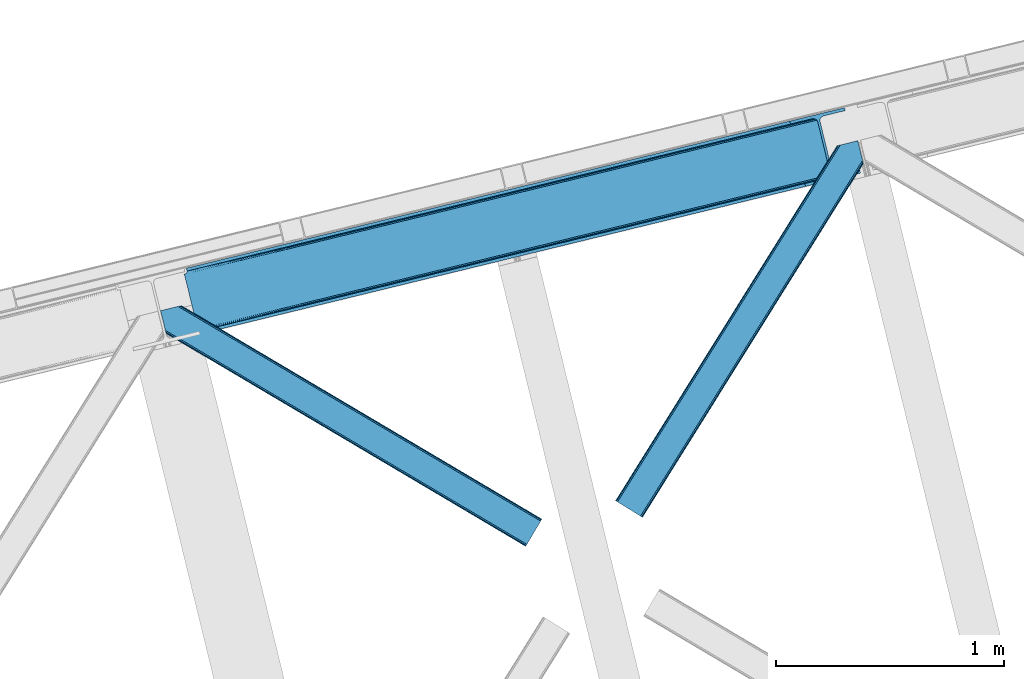
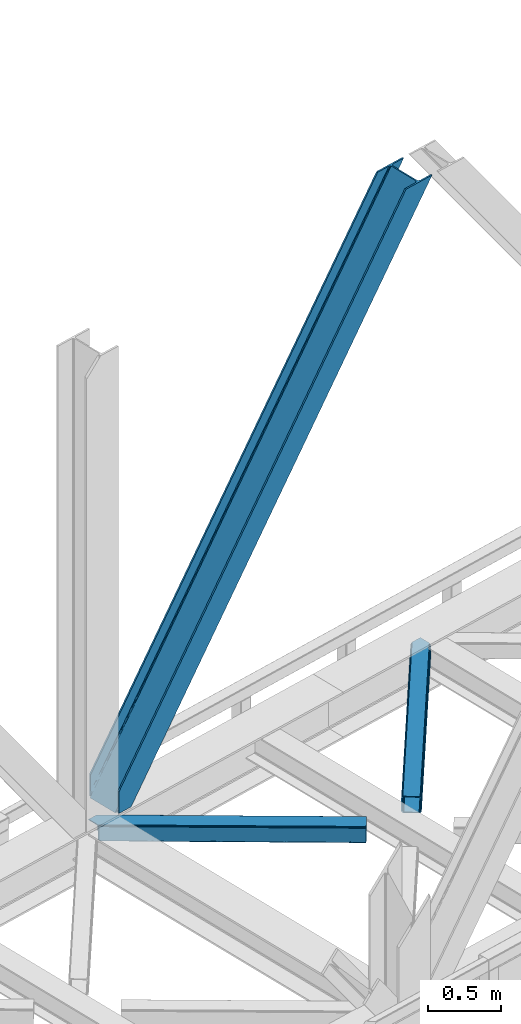
# One storey, part 64 of 92: 3 members.
"""IFC4 building model written with IfcOpenShell, lengths in millimetres."""

from ifc_helpers import new_model, entity, si_unit, converted_unit, derived_unit, direction, frame, origin, place, context, subcontext, project, spatial, triangles, type_object, element, save


model = new_model("IFC4")

# Units and contexts
model_context = context("Model", 3, precision=0.01, world=origin(), true_north=direction((6.12303176911189e-17, 1.0)))
plan_context = context("Plan", 3, precision=0.01, world=origin(), true_north=direction((6.12303176911189e-17, 1.0)))
body_context = subcontext(model_context, "Body", "Model", "MODEL_VIEW")
ifc_project = project(units=[si_unit("LENGTHUNIT", "METRE", prefix="MILLI"), si_unit("AREAUNIT", "SQUARE_METRE"), si_unit("VOLUMEUNIT", "CUBIC_METRE"), converted_unit("PLANEANGLEUNIT", "DEGREE", entity("IfcRatioMeasure", 0.0174532925199433), si_unit("PLANEANGLEUNIT", "RADIAN"), dimensions=[0, 0, 0, 0, 0, 0, 0]), si_unit("MASSUNIT", "GRAM", prefix="KILO"), derived_unit("MASSDENSITYUNIT", [(si_unit("MASSUNIT", "GRAM", prefix="KILO"), 1), (si_unit("LENGTHUNIT", "METRE"), -3)]), derived_unit("MOMENTOFINERTIAUNIT", [(si_unit("LENGTHUNIT", "METRE"), 4)]), si_unit("TIMEUNIT", "SECOND"), si_unit("FREQUENCYUNIT", "HERTZ"), si_unit("THERMODYNAMICTEMPERATUREUNIT", "DEGREE_CELSIUS"), derived_unit("THERMALTRANSMITTANCEUNIT", [(si_unit("MASSUNIT", "GRAM", prefix="KILO"), 1), (si_unit("THERMODYNAMICTEMPERATUREUNIT", "KELVIN"), -1), (si_unit("TIMEUNIT", "SECOND"), -3)]), derived_unit("VOLUMETRICFLOWRATEUNIT", [(si_unit("LENGTHUNIT", "METRE"), 3), (si_unit("TIMEUNIT", "SECOND"), -1)]), derived_unit("MASSFLOWRATEUNIT", [(si_unit("MASSUNIT", "GRAM", prefix="KILO"), 1), (si_unit("TIMEUNIT", "SECOND"), -1)]), derived_unit("ROTATIONALFREQUENCYUNIT", [(si_unit("TIMEUNIT", "SECOND"), -1)]), si_unit("ELECTRICCURRENTUNIT", "AMPERE"), si_unit("ELECTRICVOLTAGEUNIT", "VOLT"), si_unit("POWERUNIT", "WATT"), si_unit("FORCEUNIT", "NEWTON", prefix="KILO"), si_unit("ILLUMINANCEUNIT", "LUX"), si_unit("LUMINOUSFLUXUNIT", "LUMEN"), si_unit("LUMINOUSINTENSITYUNIT", "CANDELA"), derived_unit("USERDEFINED", [(si_unit("MASSUNIT", "GRAM", prefix="KILO"), -1), (si_unit("LENGTHUNIT", "METRE"), -2), (si_unit("TIMEUNIT", "SECOND"), 3), (si_unit("LUMINOUSFLUXUNIT", "LUMEN"), 1)]), derived_unit("LINEARVELOCITYUNIT", [(si_unit("LENGTHUNIT", "METRE"), 1), (si_unit("TIMEUNIT", "SECOND"), -1)]), si_unit("PRESSUREUNIT", "PASCAL"), derived_unit("USERDEFINED", [(si_unit("LENGTHUNIT", "METRE"), -2), (si_unit("MASSUNIT", "GRAM", prefix="KILO"), 1), (si_unit("TIMEUNIT", "SECOND"), -2)]), derived_unit("LINEARFORCEUNIT", [(si_unit("MASSUNIT", "GRAM", prefix="KILO"), 1), (si_unit("LENGTHUNIT", "METRE"), 1), (si_unit("TIMEUNIT", "SECOND"), -2), (si_unit("LENGTHUNIT", "METRE"), -1)]), derived_unit("PLANARFORCEUNIT", [(si_unit("MASSUNIT", "GRAM", prefix="KILO"), 1), (si_unit("LENGTHUNIT", "METRE"), 1), (si_unit("TIMEUNIT", "SECOND"), -2), (si_unit("LENGTHUNIT", "METRE"), -2)])], contexts=[model_context, plan_context])

# Site, building, storey
site_placement = place(None, origin())
site = spatial("IfcSite", under=ifc_project, at=site_placement, CompositionType="ELEMENT")
building_placement = place(site_placement, origin())
building = spatial("IfcBuilding", under=site, at=building_placement, CompositionType="ELEMENT")
storey_placement = place(building_placement, frame((0.0, 0.0, 15900.0)))
storey = spatial("IfcBuildingStorey", under=building, at=storey_placement, Name="05", CompositionType="ELEMENT", Elevation=15900.0)

# Members
member_type_1 = type_object("IfcMemberType", PredefinedType="BRACE")
member_1_placement = place(storey_placement, frame((-23912.66, 14831.12, 3695.0)))
element("IfcMember", 1, at=member_1_placement, inside=storey, type_object=member_type_1, ObjectType="Steel Vertical Brace", PredefinedType="BRACE", context=body_context, shape_type="Tessellation", body=[
    triangles([(58.5452636718765, 26.6239562988267, 0.0), (60.4404968261733, 18.8511749267564, 0.0), (59.1033691406265, 19.6697296142574, 0.80925292968459), (58.9708190917991, 18.4930572509766, 1.10690917968532), (64.0867858886741, 19.7406555175767, 8.31577148437282), (64.0867858886741, 19.7406555175767, 0.0), (522.905291748048, 126.716683959959, 658.855133056641), (68.3748962402351, 19.9232025146484, 14.8293273925774), (72.4072082519524, 18.4523620605469, 22.4381652832017), (524.584259033203, 133.136059570312, 656.552947998047), (73.9861816406265, 17.2873168945298, 26.4425720214822), (2834.75487670899, 696.263314819334, 3911.00081176758), (2834.77115478516, 703.35823059082, 3911.00081176758), (2385.95203857422, 593.953280639647, 3278.7231262207), (2386.50781860352, 586.999053955078, 3279.53005371094), (2831.44112548828, 689.4462890625, 3911.00081176758), (2384.82652587891, 580.578515624999, 3281.83223876953), (2825.33917236328, 683.941973876952, 3911.00081176758), (2381.17326049805, 575.671838378905, 3285.27854003906), (2817.37686767578, 680.591015624999, 3911.00081176758), (2376.09450073242, 573.023162841797, 3289.34108276367), (514.168615722658, 119.160168457031, 666.36397705078), (519.249700927736, 121.807681274413, 662.301434326171), (77.0976196289084, 12.6189971923814, 50.6410949707024), (76.5674194335952, 13.8991516113274, 38.6743835449197), (75.4046997070327, 15.4258026123043, 33.1630920410134), (524.026153564453, 140.089123535156, 655.74602050781), (990.065148925783, 246.601226806641, 1312.29896850586), (989.509368896484, 253.55545349121, 1311.48971557617), (1455.54603881836, 360.067556762695, 1968.04266357422), (1454.99025878906, 367.021783447264, 1967.23341064453), (1921.02692871094, 473.532723999022, 2623.78635864258), (1920.47114868164, 480.48811340332, 2622.97710571289), (988.383856201173, 240.181851196288, 1314.598828125), (1453.86474609375, 353.647018432617, 1970.34484863281), (1919.34563598633, 467.113348388672, 2626.08854370117), (984.730590820313, 235.274011230467, 1318.04512939453), (1450.21148071289, 348.740341186523, 1973.78882446289), (1915.69237060547, 462.206671142578, 2629.53251953125), (979.651831054689, 232.626498413085, 1322.10767211914), (1445.13272094727, 346.091665649414, 1977.85369262695), (1910.61361083985, 459.557995605468, 2633.59738769531), (77.0976196289084, 12.6189971923814, 182.433050537107), (2723.82443847656, 657.786593627929, 3911.00081176758), (75.5674804687515, 15.5502136230461, 0.0), (77.3789978027344, 11.6585906982418, 0.0), (77.3789978027344, 11.6585906982418, 182.495837402341), (68.3748962402351, 19.9232025146484, 0.0), (72.4072082519524, 18.4523620605469, 0.0), (2726.9033203125, 645.157131958007, 3911.00081176758), (80.2206848144524, 0.0, 182.495837402341), (80.2206848144524, 0.0, 0.0), (191.327856445314, 27.0832305908189, 0.0), (2967.5537475586, 703.817504882813, 3911.00081176758), (1399.80990600586, 593.394012451172, 1967.23341064453), (2779.59080200195, 929.729296874999, 3911.00081176758), (2330.77168579102, 820.325509643553, 3278.7231262207), (1865.29079589844, 706.859179687499, 2622.97710571289), (934.329016113283, 479.927682495116, 1311.48971557617), (468.845800781251, 366.461352539061, 655.74602050781), (3.36491088867115, 252.995022583007, 0.0), (2964.47486572266, 716.448129272459, 3911.00081176758), (188.248974609374, 39.7138549804677, 0.0), (2870.92243652344, 693.643707275391, 3911.00081176758), (94.6965454101555, 16.909432983397, 0.0), (2862.31133422852, 692.954214477539, 3911.00081176758), (86.083117675782, 16.2199401855469, 0.0), (2854.36065673828, 695.033157348633, 3911.00081176758), (78.1324401855491, 18.2977203369137, 0.0), (2848.28195800781, 699.561950683594, 3911.00081176758), (72.0537414550781, 22.8265136718746, 0.0), (2845.00076293945, 705.852264404297, 3911.00081176758), (68.7725463867209, 29.1168273925778, 0.0), (2789.82041015625, 932.223330688475, 3911.00081176758), (13.5921936035156, 255.489056396484, 0.0), (2789.83901367188, 939.318246459959, 3911.00081176758), (13.6107971191414, 262.582809448242, 0.0), (2793.15043945313, 946.136434936523, 3911.00081176758), (16.9222229003899, 269.400997924804, 0.0), (2799.25239257812, 951.639587402344, 3911.00081176758), (23.0241760253921, 274.904150390625, 0.0), (2807.21702270508, 954.990545654297, 3911.00081176758), (30.9911315917961, 278.256271362305, 0.0), (2900.7694519043, 977.794967651367, 3911.00081176758), (124.543560791015, 301.060693359374, 0.0), (2897.69057006836, 990.425592041014, 3911.00081176758), (121.464678955079, 313.691317749022, 0.0), (2770.23323364258, 940.54956665039, 3911.00081176758), (2762.28255615235, 942.627346801757, 3911.00081176758), (2657.04014282226, 931.764056396483, 3911.00081176758), (2753.67145385742, 941.939016723632, 3911.00081176758), (2660.1190246582, 919.134594726562, 3911.00081176758), (2776.3096069336, 936.020773315429, 3911.00081176758), (10.3575073242209, 286.606924438476, 182.495837402341), (10.3575073242209, 286.606924438476, 0.0), (13.199194335939, 274.948333740234, 182.495837402341), (13.3922058105491, 273.966998291015, 182.433050537107), (1381.42498168946, 607.439666748047, 1977.85369262695), (1846.90587158203, 720.904833984374, 2633.59738769531), (2312.38676147461, 834.371163940428, 3289.34108276367), (915.94641723633, 493.973336791991, 1322.10767211914), (13.3922058105491, 273.966998291015, 50.6410949707024), (450.463201904298, 380.507006835936, 666.36397705078), (13.199194335939, 274.948333740234, 0.0), (13.5084777832053, 272.584524536132, 38.6743835449197), (13.3829040527344, 270.661386108397, 0.0), (13.3829040527344, 270.661386108397, 32.1678039550752), (12.4783081054702, 268.182467651366, 26.1867736816384), (11.9109008789055, 266.62907409668, 22.4381652832017), (11.9109008789055, 266.62907409668, 0.0), (9.00875244140843, 263.467639160155, 14.8293273925774), (9.00875244140843, 263.467639160155, 0.0), (5.11829223632958, 261.657284545898, 8.31577148437282), (5.11829223632958, 261.657284545898, 0.0), (1.46967773437427, 260.767803955077, 0.0), (461.697399902343, 377.818798828124, 658.855133056641), (456.190759277346, 380.493054199218, 662.301434326171), (466.141314697266, 372.892355346679, 656.552947998047), (0.660424804689683, 259.426025390625, 0.80925292968459), (0.0, 260.409686279296, 1.10690917968532), (2318.11664428711, 834.35721130371, 3285.27854003906), (2323.61630859375, 831.681793212891, 3281.83223876953), (2328.06487426758, 826.755349731444, 3279.53005371094), (921.673974609377, 493.959384155272, 1318.04512939453), (1387.15486450195, 607.425714111327, 1973.78882446289), (1852.63575439453, 720.890881347656, 2629.53251953125), (927.175964355469, 491.285128784179, 1314.598828125), (1392.65685424805, 604.750296020507, 1970.34484863281), (1858.13774414063, 718.216625976562, 2626.08854370117), (931.622204589843, 486.357522583006, 1312.29896850586), (1397.10309448242, 599.823852539063, 1968.04266357422), (1862.583984375, 713.290182495117, 2623.78635864258)], [[1, 2, 3], [4, 3, 2], [5, 4, 6], [2, 6, 4], [7, 8, 9], [10, 3, 8], [8, 7, 10], [9, 11, 7], [3, 4, 5], [5, 8, 3], [12, 13, 14], [14, 15, 12], [16, 12, 15], [15, 17, 16], [18, 16, 17], [17, 19, 18], [20, 18, 19], [19, 21, 20], [22, 23, 24], [25, 24, 23], [25, 7, 26], [25, 23, 7], [11, 26, 7], [10, 27, 3], [1, 3, 27], [28, 29, 10], [27, 10, 29], [30, 31, 28], [29, 28, 31], [32, 33, 31], [31, 30, 32], [15, 14, 33], [33, 32, 15], [34, 28, 7], [10, 7, 28], [35, 30, 34], [28, 34, 30], [36, 32, 35], [30, 35, 32], [17, 15, 36], [32, 36, 15], [37, 34, 7], [7, 23, 37], [38, 35, 34], [34, 37, 38], [39, 36, 35], [35, 38, 39], [19, 17, 36], [36, 39, 19], [40, 37, 22], [23, 22, 37], [41, 38, 40], [37, 40, 38], [42, 39, 41], [38, 41, 39], [21, 19, 42], [39, 42, 19], [41, 43, 44], [44, 21, 42], [21, 44, 20], [42, 41, 44], [43, 41, 40], [40, 22, 43], [24, 43, 22], [45, 11, 9], [45, 26, 11], [46, 25, 26], [46, 47, 24], [43, 24, 47], [24, 25, 46], [26, 45, 46], [48, 8, 5], [5, 6, 48], [49, 9, 8], [8, 48, 49], [9, 49, 45], [47, 44, 43], [50, 47, 51], [47, 50, 44], [52, 51, 46], [47, 46, 51], [50, 53, 54], [53, 50, 51], [52, 53, 51], [33, 55, 31], [13, 56, 57], [58, 14, 57], [55, 33, 58], [57, 14, 13], [58, 33, 14], [31, 59, 29], [59, 60, 27], [59, 31, 55], [61, 1, 60], [59, 27, 29], [60, 1, 27], [62, 54, 53], [53, 63, 62], [64, 62, 63], [63, 65, 64], [66, 64, 65], [65, 67, 66], [68, 66, 67], [67, 69, 68], [70, 68, 69], [69, 71, 70], [72, 70, 71], [71, 73, 72], [74, 72, 75], [73, 75, 72], [76, 74, 77], [75, 77, 74], [78, 76, 79], [77, 79, 76], [80, 78, 81], [79, 81, 78], [82, 80, 83], [81, 83, 80], [84, 82, 85], [83, 85, 82], [86, 84, 85], [85, 87, 86], [56, 13, 74], [16, 18, 66], [20, 50, 54], [44, 50, 20], [18, 20, 64], [13, 12, 70], [12, 16, 68], [88, 80, 89], [90, 91, 86], [91, 89, 82], [90, 92, 91], [88, 93, 78], [93, 56, 76], [74, 13, 72], [64, 66, 18], [70, 12, 68], [66, 68, 16], [70, 72, 13], [54, 64, 20], [54, 62, 64], [82, 89, 80], [78, 93, 76], [74, 76, 56], [78, 80, 88], [82, 86, 91], [86, 82, 84], [90, 87, 94], [90, 86, 87], [87, 95, 94], [96, 90, 94], [92, 96, 97], [96, 92, 90], [92, 97, 98], [98, 99, 92], [99, 100, 92], [91, 92, 100], [101, 98, 97], [97, 102, 103], [103, 101, 97], [104, 96, 94], [94, 95, 104], [104, 105, 102], [104, 106, 107], [107, 105, 104], [96, 104, 102], [102, 97, 96], [108, 106, 109], [108, 107, 106], [110, 109, 106], [109, 110, 111], [112, 111, 110], [111, 112, 113], [114, 113, 112], [75, 73, 61], [114, 75, 61], [114, 112, 75], [114, 61, 115], [79, 77, 110], [77, 75, 112], [106, 79, 110], [110, 77, 112], [73, 1, 61], [6, 73, 48], [1, 6, 2], [1, 73, 6], [48, 71, 49], [49, 71, 69], [73, 71, 48], [45, 49, 69], [104, 81, 79], [79, 106, 104], [95, 81, 104], [83, 95, 87], [87, 85, 83], [83, 81, 95], [45, 69, 46], [52, 67, 65], [46, 69, 67], [52, 46, 67], [65, 53, 52], [53, 65, 63], [116, 117, 105], [105, 107, 116], [118, 111, 113], [113, 119, 118], [118, 116, 108], [108, 109, 118], [109, 111, 118], [113, 120, 119], [107, 108, 116], [117, 103, 102], [102, 105, 117], [89, 91, 121], [100, 121, 91], [88, 89, 122], [121, 122, 89], [93, 88, 123], [122, 123, 88], [56, 93, 57], [123, 57, 93], [124, 101, 103], [103, 117, 124], [125, 98, 101], [101, 124, 125], [126, 99, 98], [98, 125, 126], [121, 100, 99], [99, 126, 121], [127, 124, 116], [117, 116, 124], [128, 125, 127], [124, 127, 125], [129, 126, 128], [125, 128, 126], [122, 121, 129], [126, 129, 121], [130, 127, 116], [116, 118, 130], [131, 128, 130], [127, 130, 128], [132, 129, 131], [128, 131, 129], [123, 122, 129], [129, 132, 123], [60, 118, 119], [119, 61, 60], [59, 130, 118], [118, 60, 59], [55, 131, 130], [130, 59, 55], [58, 132, 131], [131, 55, 58], [57, 123, 58], [132, 58, 123], [120, 113, 114], [114, 115, 120], [115, 61, 119], [119, 120, 115]]),
])
member_type_2 = type_object("IfcMemberType", PredefinedType="BRACE")
member_2_placement = place(storey_placement, frame((-22019.95, 14024.23, 3510.0)))
element("IfcMember", 2, at=member_2_placement, inside=storey, type_object=member_type_2, ObjectType="Steel Horizontal Brace", PredefinedType="BRACE", context=body_context, shape_type="Tessellation", body=[
    triangles([(933.019793701169, 1535.69230957031, 0.0), (967.778137207031, 1393.09171142578, 0.0), (14.843280029294, 64.8692962646492, 0.0), (103.912261962891, 9.26687622070313, 0.0), (928.801446533202, 1552.99125366211, 5.49966430664063), (928.943298339844, 1552.41570739746, 5.20782165527635), (930.801324462889, 1544.78710327148, 1.33247680664135), (971.996484374999, 1375.79276733399, 5.49966430664063), (971.856958007811, 1376.36715087891, 5.20782165527635), (969.996606445311, 1383.99691772461, 1.33247680664135), (972.20577392578, 1375.53696899414, 5.85313110351854), (972.422039794921, 1375.28349609375, 6.20659790039281), (928.910742187498, 1553.56912536621, 5.74383544921875), (972.724346923827, 1375.53813171387, 6.35310058594041), (929.024688720703, 1554.17606506348, 5.9996337890625), (973.024328613279, 1375.79276733399, 6.49960327148438), (929.145611572265, 1554.78416748047, 6.25659484863354), (929.252581787106, 1555.36203918457, 6.49960327148438), (4.34624633788917, 71.4223846435561, 5.12526855468968), (1.12783813476563, 73.4304016113292, 10.8028289794929), (973.359191894531, 1630.84231567383, 10.8028289794929), (976.914788818358, 1631.70970458984, 6.49960327148438), (9.1622314453125, 68.4155914306648, 1.33247680664135), (971.505816650388, 1630.39118041992, 17.5000946044929), (0.0, 74.1361724853523, 17.5000946044929), (1081.09912719726, 1548.91708374024, 6.49960327148438), (1056.20762329101, 1651.03759460449, 6.49960327148438), (971.505816650388, 1630.39118041992, 122.500662231447), (0.0, 74.1361724853523, 122.500662231447), (973.359191894531, 1630.84231567383, 129.197927856447), (1.12783813476563, 73.4304016113292, 129.197927856447), (978.630963134765, 1632.12828369141, 134.874325561526), (4.34624633788917, 71.4223846435561, 134.874325561526), (986.525830078124, 1634.05258483887, 138.667117309571), (9.1622314453125, 68.4155914306648, 138.667117309571), (995.83921508789, 1636.32221374512, 139.999594116212), (14.843280029294, 64.8692962646492, 139.999594116212), (118.757867431639, 0.0, 17.5000946044929), (117.627703857419, 0.704608154297603, 10.8028289794929), (1085.1407409668, 1551.25066223145, 10.9783996582046), (1087.41502075195, 1552.56453552246, 13.5003387451179), (109.593310546872, 5.7205810546875, 1.33247680664135), (114.409295654295, 2.71378784179797, 5.12526855468968), (1087.56849975586, 1551.93550415039, 17.5000946044929), (1081.77583007812, 1575.70149536133, 139.999594116212), (1063.00720825195, 1652.69563293457, 139.999594116212), (103.912261962891, 9.26687622070313, 139.999594116212), (1083.99197387695, 1566.60670166016, 138.667117309571), (109.593310546872, 5.7205810546875, 138.667117309571), (1085.87092895508, 1558.89670715332, 134.874325561526), (114.409295654295, 2.71378784179797, 134.874325561526), (1087.12666625976, 1553.74469604492, 129.197927856447), (117.627703857419, 0.704608154297603, 129.197927856447), (1087.56849975586, 1551.93550415039, 122.500662231447), (118.757867431639, 0.0, 122.500662231447), (1082.53392333984, 1566.77297058106, 12.1260040283232), (1083.96406860351, 1566.72413635254, 13.5003387451179), (1077.85048828125, 1569.98556518555, 8.3320495605476), (1074.64370727539, 1577.50022277832, 6.99957275390625), (1056.69131469727, 1651.1561920166, 6.99957275390625), (1005.57117919922, 1638.69532470703, 6.99957275390625), (20.7824523925774, 61.1625457763676, 6.99957275390625), (97.9777404785127, 12.974789428712, 6.99957275390625), (108.474774169921, 6.42170104980505, 12.1260040283232), (111.693182373045, 4.41252136230469, 17.8035644531265), (1084.81052856445, 1563.2510925293, 17.8035644531265), (103.658789062498, 9.42733154296911, 8.3320495605476), (1085.25236206055, 1561.44190063477, 24.4996673583992), (112.82102050781, 3.70675048828161, 24.4996673583992), (983.091156005859, 1633.21542663574, 17.8035644531265), (981.24010620117, 1632.76429138184, 24.4996673583992), (7.06701049804542, 69.7248138427749, 17.8035644531265), (5.93917236327979, 70.430584716798, 24.4996673583992), (988.365252685544, 1634.50023193359, 12.1260040283232), (10.285418701169, 67.7156341552745, 12.1260040283232), (996.257794189452, 1636.42453308106, 8.3320495605476), (15.1014038085923, 64.7088409423832, 8.3320495605476), (981.24010620117, 1632.76429138184, 115.501089477541), (5.93917236327979, 70.430584716798, 115.501089477541), (996.257794189452, 1636.42453308106, 131.667544555665), (1005.57117919922, 1638.69532470703, 133.000021362306), (1063.00720825195, 1652.69563293457, 133.000021362306), (988.365252685544, 1634.50023193359, 127.87475280762), (983.091156005859, 1633.21542663574, 122.196029663086), (20.7824523925774, 61.1625457763676, 133.000021362306), (15.1014038085923, 64.7088409423832, 131.667544555665), (10.285418701169, 67.7156341552745, 127.87475280762), (7.06701049804542, 69.7248138427749, 122.196029663086), (108.474774169921, 6.42170104980505, 127.87475280762), (111.693182373045, 4.41252136230469, 122.196029663086), (112.82102050781, 3.70675048828161, 115.501089477541), (97.9777404785127, 12.974789428712, 133.000021362306), (103.658789062498, 9.42733154296911, 131.667544555665), (1085.25236206055, 1561.44190063477, 115.501089477541), (1084.81052856445, 1563.2510925293, 122.196029663086), (1083.55479125976, 1568.4031036377, 127.87475280762), (1081.67583618164, 1576.11309814453, 131.667544555665), (1079.45736694336, 1585.2078918457, 133.000021362306)], [[1, 2, 3], [4, 3, 2], [1, 5, 2], [6, 5, 1], [1, 7, 6], [2, 5, 8], [8, 9, 2], [10, 2, 9], [11, 8, 5], [12, 11, 13], [14, 12, 15], [16, 14, 17], [17, 18, 16], [15, 17, 14], [13, 15, 12], [5, 13, 11], [17, 19, 18], [19, 17, 15], [13, 19, 15], [19, 13, 5], [5, 6, 19], [20, 21, 18], [18, 19, 20], [21, 22, 18], [19, 6, 7], [7, 1, 23], [3, 23, 1], [7, 23, 19], [24, 21, 20], [20, 25, 24], [18, 26, 16], [26, 18, 22], [27, 26, 22], [28, 24, 29], [25, 29, 24], [30, 28, 31], [29, 31, 28], [32, 30, 33], [31, 33, 30], [34, 32, 35], [33, 35, 32], [36, 34, 37], [35, 37, 34], [38, 39, 40], [40, 41, 38], [42, 10, 9], [39, 12, 16], [16, 40, 39], [16, 26, 40], [9, 39, 43], [9, 12, 39], [9, 43, 42], [2, 10, 4], [42, 4, 10], [41, 44, 38], [45, 36, 37], [36, 45, 46], [37, 47, 45], [48, 45, 47], [47, 49, 48], [50, 48, 49], [49, 51, 50], [52, 50, 51], [51, 53, 52], [54, 52, 53], [53, 55, 54], [44, 54, 38], [55, 38, 54], [56, 40, 26], [41, 40, 56], [56, 57, 41], [58, 26, 59], [26, 58, 56], [60, 59, 26], [59, 61, 62], [61, 59, 60], [62, 63, 59], [64, 65, 66], [66, 57, 64], [58, 59, 63], [63, 67, 58], [56, 58, 67], [67, 64, 56], [57, 56, 64], [68, 66, 65], [65, 69, 68], [70, 71, 72], [73, 72, 71], [74, 70, 75], [72, 75, 70], [76, 74, 77], [75, 77, 74], [61, 76, 62], [77, 62, 76], [71, 78, 79], [79, 73, 71], [34, 36, 80], [46, 81, 36], [81, 46, 82], [81, 80, 36], [83, 34, 80], [83, 32, 34], [32, 84, 30], [84, 32, 83], [28, 84, 78], [84, 28, 30], [61, 22, 76], [70, 74, 22], [74, 76, 22], [61, 60, 22], [71, 70, 24], [21, 24, 70], [28, 71, 24], [71, 28, 78], [70, 22, 21], [80, 81, 85], [85, 86, 80], [83, 80, 86], [86, 87, 83], [84, 83, 87], [87, 88, 84], [78, 84, 88], [88, 79, 78], [53, 89, 90], [91, 38, 55], [53, 90, 55], [53, 51, 89], [90, 91, 55], [89, 51, 49], [92, 47, 37], [47, 93, 49], [93, 47, 92], [93, 89, 49], [39, 64, 43], [69, 38, 91], [38, 65, 39], [65, 38, 69], [39, 65, 64], [4, 63, 3], [42, 43, 64], [64, 67, 42], [67, 63, 4], [4, 42, 67], [87, 35, 33], [37, 85, 92], [37, 86, 85], [86, 37, 35], [87, 86, 35], [79, 29, 25], [31, 88, 87], [33, 31, 87], [88, 31, 29], [79, 88, 29], [23, 75, 19], [3, 63, 62], [62, 77, 3], [77, 75, 23], [23, 3, 77], [20, 19, 75], [25, 73, 79], [72, 25, 20], [25, 72, 73], [72, 20, 75], [66, 41, 57], [54, 44, 68], [44, 66, 68], [68, 94, 54], [44, 41, 66], [95, 54, 94], [52, 54, 95], [50, 95, 96], [95, 50, 52], [96, 48, 50], [97, 48, 96], [97, 98, 45], [97, 45, 48], [98, 46, 45], [98, 82, 46], [81, 98, 85], [81, 82, 98], [92, 85, 98], [95, 94, 90], [91, 90, 94], [96, 95, 89], [90, 89, 95], [97, 96, 93], [89, 93, 96], [98, 97, 92], [93, 92, 97], [94, 68, 91], [69, 91, 68]]),
])
member_type_3 = type_object("IfcMemberType", PredefinedType="BRACE")
member_3_placement = place(storey_placement, frame((-24015.39, 13897.01, 3510.0)))
element("IfcMember", 3, at=member_3_placement, inside=storey, type_object=member_type_3, ObjectType="Steel Horizontal Brace", PredefinedType="BRACE", context=body_context, shape_type="Tessellation", body=[
    triangles([(1672.88858642578, 120.470553588866, 122.500662231447), (1672.88858642578, 120.470553588866, 17.5000946044929), (91.5013916015632, 1056.69131469727, 17.5000946044929), (91.5013916015632, 1056.69131469727, 122.500662231447), (1663.97517700195, 105.412170410156, 139.999594116212), (1667.38659667969, 111.174609374999, 138.667117309571), (76.4813781738267, 1053.02991027832, 138.667117309571), (67.167993164061, 1050.76028137207, 139.999594116212), (1670.27944335937, 116.060357666016, 134.874325561526), (84.3739196777351, 1054.95421142578, 134.874325561526), (1672.21188354492, 119.324111938477, 129.197927856447), (89.6503417968743, 1056.24017944336, 129.197927856447), (18.7662963867188, 957.393887329101, 139.999594116212), (1610.48309326172, 15.0583831787098, 139.999594116212), (0.0, 1034.38686218262, 139.999594116212), (1601.56968383789, 0.0, 122.500662231447), (1602.24638671875, 1.14644165038953, 129.197927856447), (24.5612915039055, 933.626733398438, 122.500662231447), (24.1194580078118, 935.435925292968, 129.197927856447), (1604.1788269043, 4.41019592285193, 134.874325561526), (22.8637207031243, 940.587936401367, 134.874325561526), (1607.07167358399, 9.29594421386719, 138.667117309571), (20.9847656249985, 948.297930908204, 138.667117309571), (1601.56968383789, 0.0, 17.5000946044929), (24.5612915039055, 933.626733398438, 17.5000946044929), (1672.21188354492, 119.324111938477, 10.8028289794929), (89.5619750976548, 1056.21925048828, 10.8167816162131), (162.736578369142, 1012.82073669434, 10.5005218505867), (1670.27944335937, 116.060357666016, 5.12526855468968), (165.152709960938, 1007.13154907227, 5.12526855468968), (164.09696044922, 1011.46384277344, 9.50058288574292), (163.769073486328, 1011.79172973633, 9.74126586914281), (163.415606689454, 1012.14170837402, 10.0005523681648), (163.064465332031, 1012.49284973144, 10.2586761474631), (89.4689575195298, 1056.19599609375, 10.5005218505867), (1667.38659667969, 111.174609374999, 1.33247680664135), (167.031665039063, 999.420391845702, 1.33247680664135), (1663.97517700195, 105.412170410156, 0.0), (169.247808837892, 990.325598144531, 0.0), (1610.48309326172, 15.0583831787098, 0.0), (204.008477783202, 847.725, 0.0), (166.88748779297, 995.791543579102, 10.5005218505867), (72.0351379394524, 1051.94625549316, 10.5005218505867), (168.582733154297, 993.060314941406, 9.50058288574292), (168.164154052734, 993.733529663086, 9.74591674804833), (167.733947753906, 994.425347900391, 10.0005523681648), (167.306066894533, 995.118328857421, 10.2540252685576), (1666.71454467774, 110.037469482422, 12.1260040283232), (1668.64465942383, 113.301223754883, 17.8035644531265), (79.9160522460952, 1053.86823120117, 17.8035644531265), (1663.82169799805, 105.151721191405, 8.3320495605476), (169.396636962891, 989.717495727538, 8.81690368652562), (74.1140808105483, 1052.45320129395, 12.4271484375022), (171.566271972657, 980.819201660157, 6.99957275390625), (1660.40795288086, 99.3881195068352, 6.99957275390625), (1669.32601318359, 114.447665405272, 24.4996673583992), (81.7671020507805, 1054.31820373535, 24.4996673583992), (1669.32601318359, 114.447665405272, 115.501089477541), (81.7671020507805, 1054.31820373535, 115.501089477541), (74.641955566407, 1052.58226318359, 127.87475280762), (66.7470886230476, 1050.65796203613, 131.667544555665), (79.9160522460952, 1053.86823120117, 122.196029663086), (57.433703613282, 1048.38717041016, 133.000021362306), (0.0, 1034.38686218262, 133.000021362306), (1668.64465942383, 113.301223754883, 122.196029663086), (1666.71454467774, 110.037469482422, 127.87475280762), (1663.82169799805, 105.151721191405, 131.667544555665), (1660.40795288086, 99.3881195068352, 133.000021362306), (16.4501586914048, 966.900283813477, 133.000021362306), (1614.05031738281, 21.0824340820309, 133.000021362306), (1614.05031738281, 21.0824340820309, 6.99957275390625), (201.692340087891, 857.232559204102, 6.99957275390625), (1607.74837646484, 10.4342468261711, 127.87475280762), (1610.63889770508, 15.3199951171864, 131.667544555665), (1605.13690795899, 6.02405090331922, 115.501089477541), (1605.81361083984, 7.17049255371057, 122.196029663086), (1607.07167358399, 9.29594421386719, 1.33247680664135), (1607.74837646484, 10.4342468261711, 12.1260040283232), (1604.1788269043, 4.41019592285193, 5.12526855468968), (1610.63889770508, 15.3199951171864, 8.3320495605476), (1602.24638671875, 1.14644165038953, 10.8028289794929), (1605.13690795899, 6.02405090331922, 24.4996673583992), (1605.81361083984, 7.17049255371057, 17.8035644531265), (18.6663024902336, 957.804327392578, 131.667544555665), (20.5452575683594, 950.094332885743, 127.87475280762), (21.8033203125015, 944.942321777344, 122.196029663086), (22.2428283691406, 943.133129882812, 115.501089477541), (22.2428283691406, 943.133129882812, 24.4996673583992), (21.7823913574211, 945.027200317383, 17.8163543701194), (21.7591369628899, 945.117892456055, 17.5000946044929), (203.861975097658, 848.333102416993, 8.81690368652562), (206.226947021485, 838.630206298829, 1.33247680664135), (204.675878906251, 844.990283203126, 9.50058288574292), (208.105902099611, 830.920211791992, 5.12526855468968), (209.161651611328, 826.58791809082, 9.50058288574292), (204.682855224608, 843.727569580078, 10.2075164794951), (204.322412109374, 843.705477905274, 10.3540191650391), (203.964294433594, 843.684548950196, 10.5005218505867), (27.0099792480469, 946.266659545898, 12.1260040283232), (28.3471069335938, 947.654946899414, 10.5005218505867), (204.678204345702, 844.358926391602, 9.85404968261719), (32.1375732421875, 930.762954711914, 10.8179443359404), (209.136071777342, 826.383279418946, 9.88311767578125), (208.115203857422, 826.655355834961, 10.5005218505867), (208.801208496094, 826.471646118163, 10.0842681884787), (32.4980163574219, 930.626916503907, 10.5005218505867)], [[1, 2, 3], [3, 4, 1], [5, 6, 7], [7, 8, 5], [6, 9, 10], [10, 7, 6], [9, 11, 12], [12, 10, 9], [11, 1, 4], [4, 12, 11], [5, 13, 14], [13, 5, 8], [15, 13, 8], [16, 17, 18], [19, 18, 17], [17, 20, 19], [21, 19, 20], [20, 22, 21], [23, 21, 22], [22, 14, 23], [13, 23, 14], [24, 16, 18], [18, 25, 24], [26, 27, 3], [27, 26, 28], [26, 29, 30], [30, 31, 26], [26, 32, 33], [32, 26, 31], [26, 34, 28], [34, 26, 33], [28, 35, 27], [29, 36, 37], [37, 30, 29], [36, 38, 39], [39, 37, 36], [3, 2, 26], [38, 40, 41], [41, 39, 38], [28, 42, 35], [43, 35, 42], [31, 44, 45], [45, 32, 31], [32, 45, 46], [46, 33, 32], [33, 46, 47], [47, 34, 33], [34, 47, 42], [42, 28, 34], [48, 49, 50], [45, 51, 46], [45, 44, 51], [42, 47, 51], [47, 46, 51], [44, 52, 51], [48, 53, 42], [42, 51, 48], [53, 43, 42], [51, 52, 54], [54, 55, 51], [50, 53, 48], [49, 56, 57], [57, 50, 49], [56, 58, 59], [59, 57, 56], [60, 61, 7], [10, 60, 7], [10, 12, 62], [60, 10, 62], [62, 12, 4], [61, 8, 7], [15, 63, 64], [15, 8, 63], [61, 63, 8], [62, 4, 59], [57, 3, 50], [4, 57, 59], [3, 27, 50], [4, 3, 57], [35, 50, 27], [35, 53, 50], [35, 43, 53], [58, 65, 59], [62, 59, 65], [65, 66, 62], [60, 62, 66], [66, 67, 60], [61, 60, 67], [67, 68, 61], [63, 61, 68], [68, 69, 63], [68, 70, 69], [69, 64, 63], [71, 55, 72], [54, 72, 55], [11, 66, 65], [58, 2, 1], [11, 65, 1], [11, 9, 66], [65, 58, 1], [66, 9, 6], [68, 5, 14], [5, 67, 6], [67, 5, 68], [67, 66, 6], [26, 48, 29], [56, 2, 58], [2, 49, 26], [49, 2, 56], [26, 49, 48], [38, 55, 40], [36, 29, 48], [48, 51, 36], [51, 55, 38], [38, 36, 51], [73, 22, 20], [14, 70, 68], [14, 74, 70], [74, 14, 22], [73, 74, 22], [75, 16, 24], [17, 76, 73], [20, 17, 73], [76, 17, 16], [75, 76, 16], [77, 78, 79], [40, 55, 71], [71, 80, 40], [80, 78, 77], [77, 40, 80], [81, 79, 78], [24, 82, 75], [83, 24, 81], [24, 83, 82], [83, 81, 78], [70, 74, 84], [84, 69, 70], [74, 73, 85], [85, 84, 74], [73, 76, 86], [86, 85, 73], [76, 75, 87], [87, 86, 76], [75, 82, 87], [88, 87, 82], [86, 87, 18], [18, 19, 86], [21, 86, 19], [86, 21, 85], [18, 88, 25], [89, 90, 25], [25, 88, 89], [87, 88, 18], [84, 23, 13], [15, 69, 13], [64, 69, 15], [84, 85, 23], [23, 85, 21], [69, 84, 13], [44, 30, 37], [39, 44, 37], [54, 52, 39], [54, 39, 72], [30, 44, 31], [39, 52, 44], [72, 41, 91], [41, 92, 93], [41, 72, 39], [94, 93, 92], [41, 93, 91], [94, 95, 93], [83, 89, 88], [71, 72, 91], [78, 96, 97], [97, 98, 78], [98, 99, 78], [98, 100, 99], [80, 91, 93], [93, 78, 80], [78, 93, 101], [101, 96, 78], [83, 78, 99], [99, 90, 83], [90, 89, 83], [91, 80, 71], [88, 82, 83], [24, 25, 102], [79, 103, 95], [81, 102, 104], [104, 79, 81], [104, 105, 79], [95, 94, 79], [40, 77, 92], [92, 41, 40], [77, 79, 94], [94, 92, 77], [106, 81, 24], [99, 106, 25], [99, 100, 106], [25, 90, 99], [98, 104, 106], [106, 100, 98]]),
])

save(model, "model.ifc")
